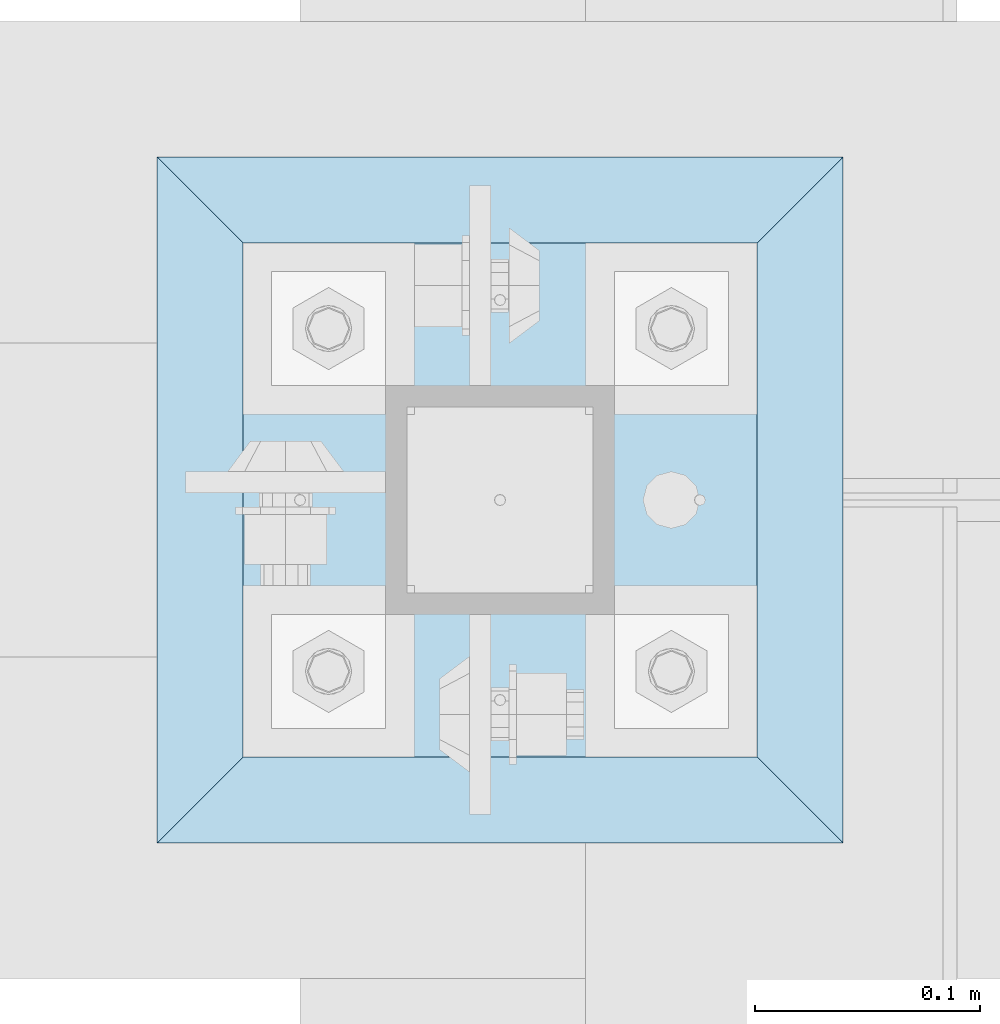
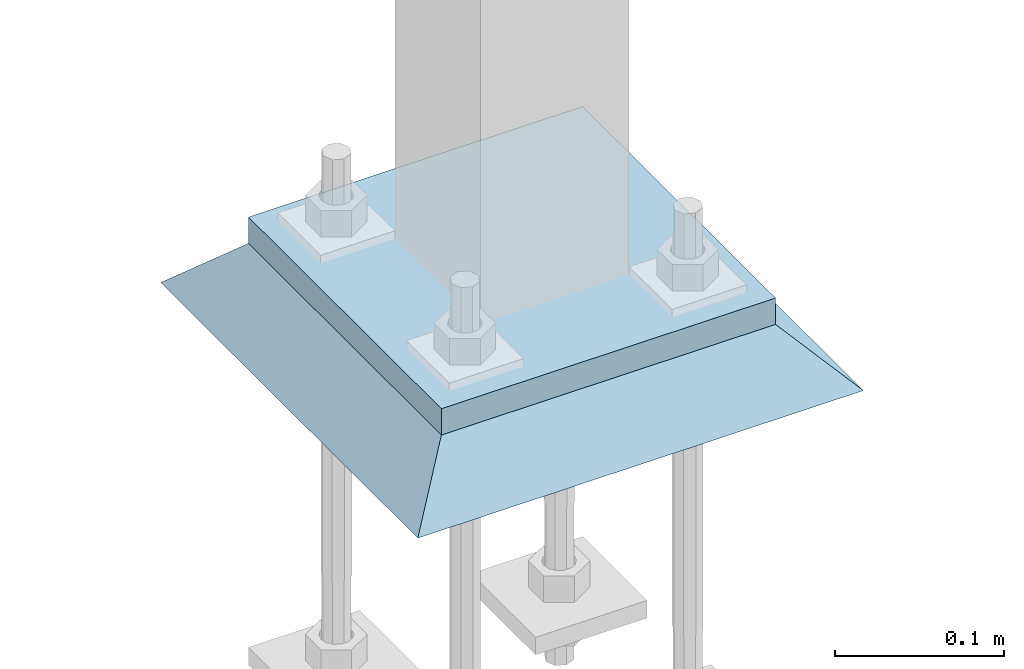
# One storey, part 3352 of 3843: 2 plates, 2 elements without a shape of their own.
"""IFC2X3 building model written with IfcOpenShell, lengths in millimetres."""

from ifc_helpers import new_model, si_unit, frame, origin_with_axes, place, context, subcontext, project, spatial, faceted_brep, material, type_object, element, aggregate, save


model = new_model("IFC2X3")

# Units and contexts
model_context = context("Model", 3, precision=1e-05, world=origin_with_axes())
body_context = subcontext(model_context, "Body", "Model", "MODEL_VIEW")
ifc_project = project(units=[si_unit("LENGTHUNIT", "METRE", prefix="MILLI"), si_unit("AREAUNIT", "SQUARE_METRE"), si_unit("VOLUMEUNIT", "CUBIC_METRE"), si_unit("MASSUNIT", "GRAM", prefix="KILO"), si_unit("TIMEUNIT", "SECOND"), si_unit("PLANEANGLEUNIT", "RADIAN"), si_unit("SOLIDANGLEUNIT", "STERADIAN"), si_unit("THERMODYNAMICTEMPERATUREUNIT", "DEGREE_CELSIUS"), si_unit("LUMINOUSINTENSITYUNIT", "LUMEN")], contexts=[model_context])

# Site, building, storey
site_placement = place(None, origin_with_axes())
site = spatial("IfcSite", under=ifc_project, at=site_placement, CompositionType="ELEMENT")
building_placement = place(site_placement, origin_with_axes())
building = spatial("IfcBuilding", under=site, at=building_placement, Name="Undefined", CompositionType="ELEMENT")
storey_placement = place(building_placement, origin_with_axes())
storey = spatial("IfcBuildingStorey", under=building, at=storey_placement, Name="Undefined", CompositionType="ELEMENT", Elevation=0.0)

# Assembly, plate
assembly_1_placement = place(storey_placement, origin_with_axes())
assembly_1 = element("IfcElementAssembly", 1, at=assembly_1_placement, inside=storey, Name="COLUMN", AssemblyPlace="NOTDEFINED", PredefinedType="RIGID_FRAME")
ifc_material_1 = material(Name="STEEL/A572-50")
plate_type_1 = type_object("IfcPlateType", PredefinedType="NOTDEFINED")
plate_1_placement = place(assembly_1_placement, frame((38706.425, 67157.6, 30070.425), z_axis=(0.0, 1.0, 0.0), x_axis=(1.0, 0.0, 0.0)))
plate_1 = element("IfcPlate", 2, at=plate_1_placement, type_object=plate_type_1, material=ifc_material_1, Name="PLATE", context=body_context, shape_type="Brep", body=[
    faceted_brep([(0.0, -9.52500000000146, 0.0), (0.0, -9.52500000000146, 228.600006103516), (0.0, 9.52500000000146, 228.600006103516), (0.0, 9.52500000000146, 0.0), (228.600006103516, -9.52500000000146, 228.600006103516), (228.600006103516, 9.52500000000146, 228.600006103516), (228.599999999999, -9.52500000000146, 0.0), (228.599999999999, 9.52500000000146, 0.0)], [[[0, 1, 2, 3]], [[1, 4, 5, 2]], [[4, 6, 7, 5]], [[6, 0, 3, 7]], [[5, 7, 3, 2]], [[6, 4, 1, 0]]]),
])
aggregate(assembly_1, [plate_1])

assembly_2_placement = place(storey_placement, origin_with_axes())
assembly_2 = element("IfcElementAssembly", 3, at=assembly_2_placement, inside=storey, Name="GROUT", AssemblyPlace="NOTDEFINED", PredefinedType="REINFORCEMENT_UNIT")
ifc_material_2 = material(Name="CONCRETE/Concrete_Undefined")
plate_type_2 = type_object("IfcPlateType", PredefinedType="NOTDEFINED")
plate_2_placement = place(assembly_2_placement, frame((38668.325, 67119.5, 30041.85), z_axis=(0.0, 1.0, 0.0), x_axis=(1.0, 0.0, 0.0)))
plate_2 = element("IfcPlate", 4, at=plate_2_placement, type_object=plate_type_2, material=ifc_material_2, Name="GROUT", context=body_context, shape_type="Brep", body=[
    faceted_brep([(38.0999999997875, -19.0499999997883, 266.699999999328), (0.0, 19.0499999999993, 304.799987792969), (0.0, 19.0500000000029, 0.0), (38.1000000006916, -19.0499999999811, 38.1000000006607), (266.700000000201, -19.0499999998174, 38.1000000006752), (304.799987792969, 19.0499999999993, 0.0), (304.799987792969, 19.0499999999993, 304.799987792969), (266.700000000201, -19.0499999999738, 266.699999999328)], [[[0, 1, 2, 3]], [[4, 5, 6, 7]], [[4, 7, 0, 3]], [[5, 4, 3, 2]], [[6, 5, 2, 1]], [[7, 6, 1, 0]]]),
])
aggregate(assembly_2, [plate_2])

save(model, "model.ifc")
